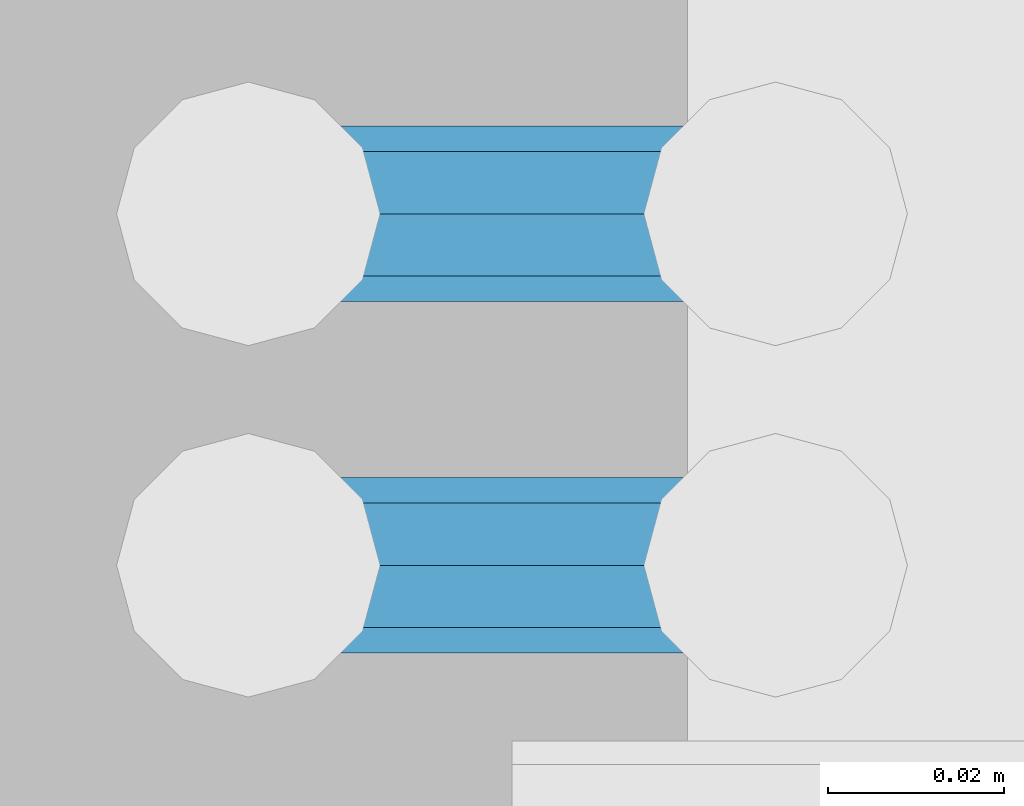
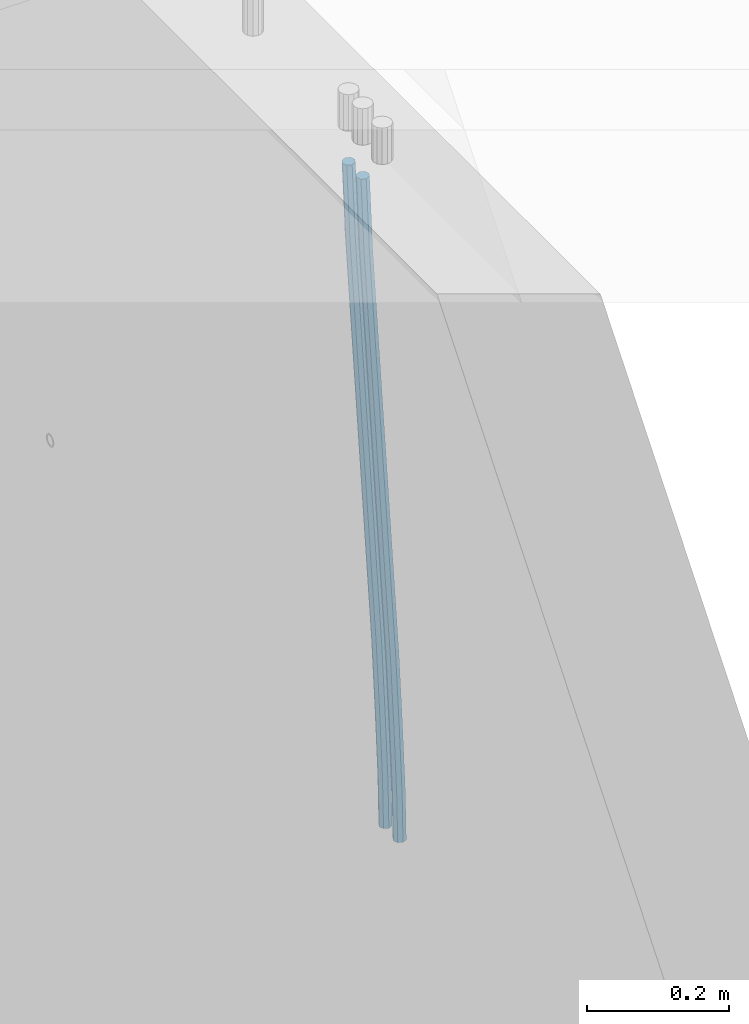
# One storey, part 110 of 350: 2 beams, 1 element without a shape of its own.
"""IFC2X3 building model written with IfcOpenShell, lengths in millimetres."""

from ifc_helpers import new_model, si_unit, frame, origin_with_axes, place, context, subcontext, project, spatial, faceted_brep, material, type_object, element, aggregate, save


model = new_model("IFC2X3")

# Units and contexts
model_context = context("Model", 3, precision=1e-05, world=origin_with_axes())
body_context = subcontext(model_context, "Body", "Model", "MODEL_VIEW")
ifc_project = project(units=[si_unit("LENGTHUNIT", "METRE", prefix="MILLI"), si_unit("AREAUNIT", "SQUARE_METRE"), si_unit("VOLUMEUNIT", "CUBIC_METRE"), si_unit("MASSUNIT", "GRAM", prefix="KILO"), si_unit("TIMEUNIT", "SECOND"), si_unit("PLANEANGLEUNIT", "RADIAN"), si_unit("SOLIDANGLEUNIT", "STERADIAN"), si_unit("THERMODYNAMICTEMPERATUREUNIT", "DEGREE_CELSIUS"), si_unit("LUMINOUSINTENSITYUNIT", "LUMEN")], contexts=[model_context])

# Site, building, storey
site_placement = place(None, origin_with_axes())
site = spatial("IfcSite", under=ifc_project, at=site_placement, CompositionType="ELEMENT")
building_placement = place(site_placement, origin_with_axes())
building = spatial("IfcBuilding", under=site, at=building_placement, CompositionType="ELEMENT")
storey_placement = place(building_placement, origin_with_axes())
storey = spatial("IfcBuildingStorey", under=building, at=storey_placement, Name="2", CompositionType="ELEMENT", Elevation=0.0)

# Assembly, beams
assembly_placement = place(storey_placement, origin_with_axes())
assembly = element("IfcElementAssembly", 1, at=assembly_placement, inside=storey, AssemblyPlace="NOTDEFINED", PredefinedType="REINFORCEMENT_UNIT")
ifc_material = material()
beam_type = type_object("IfcBeamType", Name="D20", PredefinedType="NOTDEFINED")
beam_1_placement = place(assembly_placement, frame((28670.0000022791, 9890.00000000393, 86242.5), z_axis=(-0.999820284539475, -0.000205762999905157, -0.0189566949912691), x_axis=(-0.0189566949945633, 3.09999984783362e-08, 0.999820305712423)))
beam_1 = element("IfcBeam", 2, at=beam_1_placement, type_object=beam_type, material=ifc_material, Name="JM20", ObjectType="D20", context=body_context, shape_type="Brep", body=[
    faceted_brep([(0.0, -10.0, 0.0), (-4.19531716033816e-08, -7.07106781186667, -7.07106781187031), (85.3814813058561, -7.07106783855306, -7.07106781027323), (85.3814813076606, -10.0000000266882, 1.58615875989199e-09), (0.0, 0.0, -10.0), (85.381481306933, -2.66882125288248e-08, -9.9999999984102), (4.196772351861e-08, 7.07106781186303, -7.07106781186667), (85.3814813102799, 7.07106778517664, -7.07106781027687), (0.0, 10.0, 0.0), (85.3814813139179, 9.99999997331361, 1.58979673869908e-09), (4.196772351861e-08, 7.07106781185939, 7.07106781185939), (85.3814813157223, 7.07106778517664, 7.07106781345647), (0.0, 0.0, 10.0), (85.3814813146601, -2.66863935394213e-08, 10.0000000015898), (-4.19531716033816e-08, -7.07106781187031, 7.07106781185939), (85.3814813113131, -7.07106783855306, 7.07106781345647), (86.0589861600893, -7.07106783876588, -7.07106781025868), (85.9854738744616, -10.0000000268774, 1.60071067512035e-09), (86.0894233170693, -2.69101292360574e-08, -9.99999999839565), (86.0589556716441, 7.07106778496563, -7.07106781026232), (85.9854307572532, 9.99999997312261, 1.60434865392745e-09), (85.9119184716255, 7.07106778501111, 7.07106781346374), (85.8814813146455, -2.68446456175298e-08, 10.0000000016007), (85.9119489600853, -7.07106783871859, 7.07106781346374), (86.7363445540104, -7.07106491765808, -7.05698116088388), (86.5893358725152, -9.99999742272485, 0.0125581869215239), (86.7972122870997, 3.02542866847944e-06, -9.98528050109235), (86.7362835792737, 7.07107070594066, -7.05698179489264), (86.5892496412271, 10.0000025770914, 0.0125572902979911), (86.4422409597319, 7.07107007202831, 7.08209663810703), (86.3813732266281, 2.12893792195246e-06, 10.0103959783119), (86.4423019344686, -7.07106555157225, 7.08209727211579), (201.576579767396, -7.07056966943492, -4.66871205216376), (201.429571085901, -9.99950217449987, 2.40082729564529), (201.637447500485, 0.00049827365182864, -7.59701139237222), (201.576518792659, 7.07156595416382, -4.66871268616887), (201.429484854598, 10.0004978253128, 2.40082639902175), (201.282476173117, 7.07156532024783, 9.47036574682716), (201.221608440013, 0.000497377159263124, 12.3986650870356), (201.282537147839, -7.07057030335091, 9.47036638083955), (202.132124882439, -7.07056727364943, -4.65715868644475), (201.96206784925, -9.99949987810942, 2.41190133749114), (202.202535595599, 0.000500710591950337, -7.58525956654921), (202.132054347894, 7.07156834990747, -4.65715951926177), (201.961968098345, 10.0005001216468, 2.41190015971006), (201.791911065156, 7.07156751718503, 9.48096018364595), (201.721500351996, 0.000499532941830694, 12.4090610637504), (201.791981599716, -7.07056810637368, 9.48096101645933), (202.687582846644, -7.07056412668317, -4.64198287962427), (202.494481077447, -9.99949686170658, 2.42644753327841), (202.767535042804, 0.000503911614941899, -7.5698230744747), (202.68750275379, 7.07157149682098, -4.64198397358632), (202.494367809079, 10.0005031379733, 2.42644598618062), (202.301266039882, 7.07157040295351, 9.4948763990833), (202.221313843707, 0.000502364651765674, 12.4227165939337), (202.301346132735, -7.07056522055063, 9.49487749304899), (324.551835950231, -7.0698737022467, -1.31249895472502), (324.358734181034, -9.99880643726465, 5.75593145817766), (324.631788146435, 0.00119433605323138, -4.24033914957545), (324.551755857465, 7.07226192125927, -1.31250004869435), (324.358620912724, 10.0011935624152, 5.75592991107987), (324.165519143527, 7.0722608273918, 12.8243603239825), (324.085566947324, 0.00119278909369314, 15.7522005188257), (324.165599236323, -7.06987479611053, 12.824361417941), (325.169986973066, -7.06987020009365, -1.29561029507749), (324.927897486399, -9.99880321110686, 5.771481712065), (325.270230817769, 0.001197953170049, -4.22289609669315), (325.169886630654, 7.0722654232959, -1.29561194228882), (324.927713770478, 10.0011967881728, 5.77147824025451), (324.685624283753, 7.0722637740655, 12.838570247397), (324.585380439035, 0.00119562080180913, 15.765856049009), (324.68572462615, -7.06987184932404, 12.8385718946047), (325.787844353894, -7.06986492748911, -1.27015109693093), (325.496748620091, -9.99879835819411, 5.79492186753487), (325.908370207922, 0.00120339885688736, -4.19660116572049), (325.7877237715, 7.07227069572764, -1.27015357813798), (325.496578090824, 10.0012016410783, 5.79491835858062), (325.205482357007, 7.0722682103733, 12.8599913230537), (325.084956502978, 0.00119988402911986, 15.786441391836), (325.205602939401, -7.06986741284345, 12.8599938042571), (1042.03161452286, -7.06375272341029, 28.2431194949422), (1041.74051878905, -9.99268615411529, 35.3081924594117), (1042.15214037691, 0.00731560293206712, 25.316669426149), (1042.03149394046, 7.07838289980646, 28.2431170137352), (1041.74034825979, 10.0073138451571, 35.3081889504501), (1041.44925252597, 7.07838041445029, 42.3732619149196), (1041.32872667194, 0.0073120881079376, 45.2997119837128), (1041.44937310836, -7.06375520876645, 42.3732643961303), (1042.53119058681, -7.06374846018116, 28.2637048377692), (1042.29202087625, -9.99268144776761, 35.3309174463611), (1042.66838856968, 0.00732000843709102, 25.3379417544274), (1042.62324610727, 7.07838794963754, 28.2675005302808), (1042.42220704176, 10.0073196639296, 35.3362853661929), (1042.1830373312, 7.07838667634496, 42.4034979747848), (1042.04583934831, 0.00731820772671199, 45.3292610581229), (1042.09098181075, -7.06374973347374, 42.3997022822768), (1043.03103703466, -7.070266625562, 28.2742424885473), (1042.84382145111, -9.99987711239555, 35.3425503824001), (1043.1849161698, 0.00058431523211766, 25.3488310735229), (1043.21531854615, 7.07066712639244, 28.2799824687318), (1043.10443486394, 9.99842318423725, 35.3506679402271), (1042.9172192804, 7.06881269740552, 42.4189758340799), (1042.76334014525, -0.00203824338677805, 45.3443872491043), (1042.7329377689, -7.07212105454892, 42.4132358538955), (1064.81738378434, -7.35436789656524, 28.7335373676506), (1064.63016820079, -10.283978383397, 35.8018452614997), (1064.97126291947, -0.28351695577112, 25.8081259526225), (1065.0016652958, 6.7865658553892, 28.739277347835), (1064.89078161362, 9.71432191323584, 35.8099628193268), (1064.70356603006, 6.78471142640228, 42.8782707131795), (1064.54968689493, -0.286139514393653, 45.8036821282076), (1064.51928451858, -7.35622232555033, 42.8725307329951), (1065.45272781498, -7.36265299588376, 28.7469315480957), (1065.29016895246, -10.2925850146312, 35.8157592494244), (1065.54948569229, -0.291057174725211, 25.82031591552), (1065.52376313217, 6.77975752443672, 28.7502840973975), (1065.39062806149, 9.707803747855, 35.8205004701085), (1065.22806919899, 6.77787172910939, 42.88932817143), (1065.13131132166, -0.293724092054617, 45.8159438040057), (1065.15703388178, -7.36453879121291, 42.8859756221354), (1066.08812716302, -7.36077623553683, 28.7601312146726), (1065.95022695855, -10.2906154014236, 35.8294784092541), (1066.12775920189, -0.289358859392451, 25.8323113164442), (1066.04590716431, 6.78129633325807, 28.7610959027625), (1065.89051886379, 9.70929542543126, 35.8308426842304), (1065.75261865935, 6.77945625954089, 42.9001898788119), (1065.71298662046, -0.291961116598031, 45.8280097770439), (1065.79483865805, -7.36261630925401, 42.8992251907257), (1166.09581212897, -7.06235299836771, 30.8346385453115), (1165.9579119245, -9.99219216425445, 37.903985739893), (1166.13544416784, 0.00906437777666724, 27.9068186470795), (1166.05359213027, 7.07971957042719, 30.8356032333941), (1165.89820382974, 10.0077186626022, 37.9053500148657), (1165.76030362528, 7.07787949671001, 44.9746972094508), (1165.72067158642, 0.00646212056926743, 47.9025171076792), (1165.80252362399, -7.06419307208489, 44.9737325213646)], [[[0, 1, 2, 3]], [[1, 4, 5, 2]], [[4, 6, 7, 5]], [[6, 8, 9, 7]], [[8, 10, 11, 9]], [[10, 12, 13, 11]], [[12, 14, 15, 13]], [[14, 0, 3, 15]], [[14, 12, 10, 8, 6, 4, 1, 0]], [[3, 2, 16, 17]], [[2, 5, 18, 16]], [[5, 7, 19, 18]], [[7, 9, 20, 19]], [[9, 11, 21, 20]], [[11, 13, 22, 21]], [[13, 15, 23, 22]], [[15, 3, 17, 23]], [[17, 16, 24, 25]], [[16, 18, 26, 24]], [[18, 19, 27, 26]], [[19, 20, 28, 27]], [[20, 21, 29, 28]], [[21, 22, 30, 29]], [[22, 23, 31, 30]], [[23, 17, 25, 31]], [[25, 24, 32, 33]], [[24, 26, 34, 32]], [[26, 27, 35, 34]], [[27, 28, 36, 35]], [[28, 29, 37, 36]], [[29, 30, 38, 37]], [[30, 31, 39, 38]], [[31, 25, 33, 39]], [[33, 32, 40, 41]], [[32, 34, 42, 40]], [[34, 35, 43, 42]], [[35, 36, 44, 43]], [[36, 37, 45, 44]], [[37, 38, 46, 45]], [[38, 39, 47, 46]], [[39, 33, 41, 47]], [[41, 40, 48, 49]], [[40, 42, 50, 48]], [[42, 43, 51, 50]], [[43, 44, 52, 51]], [[44, 45, 53, 52]], [[45, 46, 54, 53]], [[46, 47, 55, 54]], [[47, 41, 49, 55]], [[49, 48, 56, 57]], [[48, 50, 58, 56]], [[50, 51, 59, 58]], [[51, 52, 60, 59]], [[52, 53, 61, 60]], [[53, 54, 62, 61]], [[54, 55, 63, 62]], [[55, 49, 57, 63]], [[57, 56, 64, 65]], [[56, 58, 66, 64]], [[58, 59, 67, 66]], [[59, 60, 68, 67]], [[60, 61, 69, 68]], [[61, 62, 70, 69]], [[62, 63, 71, 70]], [[63, 57, 65, 71]], [[65, 64, 72, 73]], [[64, 66, 74, 72]], [[66, 67, 75, 74]], [[67, 68, 76, 75]], [[68, 69, 77, 76]], [[69, 70, 78, 77]], [[70, 71, 79, 78]], [[71, 65, 73, 79]], [[73, 72, 80, 81]], [[72, 74, 82, 80]], [[74, 75, 83, 82]], [[75, 76, 84, 83]], [[76, 77, 85, 84]], [[77, 78, 86, 85]], [[78, 79, 87, 86]], [[79, 73, 81, 87]], [[81, 80, 88, 89]], [[80, 82, 90, 88]], [[82, 83, 91, 90]], [[83, 84, 92, 91]], [[84, 85, 93, 92]], [[85, 86, 94, 93]], [[86, 87, 95, 94]], [[87, 81, 89, 95]], [[89, 88, 96, 97]], [[88, 90, 98, 96]], [[90, 91, 99, 98]], [[91, 92, 100, 99]], [[92, 93, 101, 100]], [[93, 94, 102, 101]], [[94, 95, 103, 102]], [[95, 89, 97, 103]], [[97, 96, 104, 105]], [[96, 98, 106, 104]], [[98, 99, 107, 106]], [[99, 100, 108, 107]], [[100, 101, 109, 108]], [[101, 102, 110, 109]], [[102, 103, 111, 110]], [[103, 97, 105, 111]], [[105, 104, 112, 113]], [[104, 106, 114, 112]], [[106, 107, 115, 114]], [[107, 108, 116, 115]], [[108, 109, 117, 116]], [[109, 110, 118, 117]], [[110, 111, 119, 118]], [[111, 105, 113, 119]], [[113, 112, 120, 121]], [[112, 114, 122, 120]], [[114, 115, 123, 122]], [[115, 116, 124, 123]], [[116, 117, 125, 124]], [[117, 118, 126, 125]], [[118, 119, 127, 126]], [[119, 113, 121, 127]], [[121, 120, 128, 129]], [[120, 122, 130, 128]], [[122, 123, 131, 130]], [[123, 124, 132, 131]], [[124, 125, 133, 132]], [[125, 126, 134, 133]], [[126, 127, 135, 134]], [[127, 121, 129, 135]], [[130, 131, 132, 133, 134, 135, 129, 128]]]),
])
beam_2_placement = place(assembly_placement, frame((28670.0000022791, 9930.00000000393, 86242.5), z_axis=(-0.999820284539475, -0.000205762999905157, -0.0189566949912691), x_axis=(-0.0189566949945633, 3.09999984783362e-08, 0.999820305712423)))
beam_2 = element("IfcBeam", 3, at=beam_2_placement, type_object=beam_type, material=ifc_material, Name="JM20", ObjectType="D20", context=body_context, shape_type="Brep", body=[
    faceted_brep([(0.0, -10.0, 0.0), (-4.19531716033816e-08, -7.07106781186667, -7.07106781187031), (85.3814813058561, -7.07106783855306, -7.07106781027323), (85.3814813076606, -10.0000000266882, 1.58615875989199e-09), (0.0, 0.0, -10.0), (85.381481306933, -2.66882125288248e-08, -9.9999999984102), (4.196772351861e-08, 7.07106781186303, -7.07106781186667), (85.3814813102799, 7.07106778517664, -7.07106781027687), (0.0, 10.0, 0.0), (85.3814813139179, 9.99999997331361, 1.58979673869908e-09), (4.196772351861e-08, 7.07106781185939, 7.07106781185939), (85.3814813157223, 7.07106778517664, 7.07106781345647), (0.0, 0.0, 10.0), (85.3814813146601, -2.66863935394213e-08, 10.0000000015898), (-4.19531716033816e-08, -7.07106781187031, 7.07106781185939), (85.3814813113131, -7.07106783855306, 7.07106781345647), (86.0589861600893, -7.07106783876588, -7.07106781025868), (85.9854738744616, -10.0000000268774, 1.60071067512035e-09), (86.0894233170693, -2.69101292360574e-08, -9.99999999839565), (86.0589556716441, 7.07106778496563, -7.07106781026232), (85.9854307572532, 9.99999997312261, 1.60434865392745e-09), (85.9119184716255, 7.07106778501111, 7.07106781346374), (85.8814813146455, -2.68446456175298e-08, 10.0000000016007), (85.9119489600853, -7.07106783871859, 7.07106781346374), (86.7363445540104, -7.07106491765808, -7.05698116088388), (86.5893358725152, -9.99999742272485, 0.0125581869215239), (86.7972122870997, 3.02542866847944e-06, -9.98528050109235), (86.7362835792737, 7.07107070594066, -7.05698179489264), (86.5892496412271, 10.0000025770914, 0.0125572902979911), (86.4422409597319, 7.07107007202831, 7.08209663810703), (86.3813732266281, 2.12893792195246e-06, 10.0103959783119), (86.4423019344686, -7.07106555157225, 7.08209727211579), (201.576579767396, -7.07056966943492, -4.66871205216376), (201.429571085901, -9.99950217449987, 2.40082729564529), (201.637447500485, 0.00049827365182864, -7.59701139237222), (201.576518792659, 7.07156595416382, -4.66871268616887), (201.429484854598, 10.0004978253128, 2.40082639902175), (201.282476173117, 7.07156532024783, 9.47036574682716), (201.221608440013, 0.000497377159263124, 12.3986650870356), (201.282537147839, -7.07057030335091, 9.47036638083955), (202.132124882439, -7.07056727364943, -4.65715868644475), (201.96206784925, -9.99949987810942, 2.41190133749114), (202.202535595599, 0.000500710591950337, -7.58525956654921), (202.132054347894, 7.07156834990747, -4.65715951926177), (201.961968098345, 10.0005001216468, 2.41190015971006), (201.791911065156, 7.07156751718503, 9.48096018364595), (201.721500351996, 0.000499532941830694, 12.4090610637504), (201.791981599716, -7.07056810637368, 9.48096101645933), (202.687582846644, -7.07056412668317, -4.64198287962427), (202.494481077447, -9.99949686170658, 2.42644753327841), (202.767535042804, 0.000503911614941899, -7.5698230744747), (202.68750275379, 7.07157149682098, -4.64198397358632), (202.494367809079, 10.0005031379733, 2.42644598618062), (202.301266039882, 7.07157040295351, 9.4948763990833), (202.221313843707, 0.000502364651765674, 12.4227165939337), (202.301346132735, -7.07056522055063, 9.49487749304899), (324.551835950231, -7.0698737022467, -1.31249895472502), (324.358734181034, -9.99880643726465, 5.75593145817766), (324.631788146435, 0.00119433605323138, -4.24033914957545), (324.551755857465, 7.07226192125927, -1.31250004869435), (324.358620912724, 10.0011935624152, 5.75592991107987), (324.165519143527, 7.0722608273918, 12.8243603239825), (324.085566947324, 0.00119278909369314, 15.7522005188257), (324.165599236323, -7.06987479611053, 12.824361417941), (325.169986973066, -7.06987020009365, -1.29561029507749), (324.927897486399, -9.99880321110686, 5.771481712065), (325.270230817769, 0.001197953170049, -4.22289609669315), (325.169886630654, 7.0722654232959, -1.29561194228882), (324.927713770478, 10.0011967881728, 5.77147824025451), (324.685624283753, 7.0722637740655, 12.838570247397), (324.585380439035, 0.00119562080180913, 15.765856049009), (324.68572462615, -7.06987184932404, 12.8385718946047), (325.787844353894, -7.06986492748911, -1.27015109693093), (325.496748620091, -9.99879835819411, 5.79492186753487), (325.908370207922, 0.00120339885688736, -4.19660116572049), (325.7877237715, 7.07227069572764, -1.27015357813798), (325.496578090824, 10.0012016410783, 5.79491835858062), (325.205482357007, 7.0722682103733, 12.8599913230537), (325.084956502978, 0.00119988402911986, 15.786441391836), (325.205602939401, -7.06986741284345, 12.8599938042571), (1042.03161452286, -7.06375272341029, 28.2431194949422), (1041.74051878905, -9.99268615411529, 35.3081924594117), (1042.15214037691, 0.00731560293206712, 25.316669426149), (1042.03149394046, 7.07838289980646, 28.2431170137352), (1041.74034825979, 10.0073138451571, 35.3081889504501), (1041.44925252597, 7.07838041445029, 42.3732619149196), (1041.32872667194, 0.0073120881079376, 45.2997119837128), (1041.44937310836, -7.06375520876645, 42.3732643961303), (1042.53119058681, -7.06374846018116, 28.2637048377692), (1042.29202087625, -9.99268144776761, 35.3309174463611), (1042.66838856968, 0.00732000843709102, 25.3379417544274), (1042.62324610727, 7.07838794963754, 28.2675005302808), (1042.42220704176, 10.0073196639296, 35.3362853661929), (1042.1830373312, 7.07838667634496, 42.4034979747848), (1042.04583934831, 0.00731820772671199, 45.3292610581229), (1042.09098181075, -7.06374973347374, 42.3997022822768), (1043.03103703466, -7.070266625562, 28.2742424885473), (1042.84382145111, -9.99987711239555, 35.3425503824001), (1043.1849161698, 0.00058431523211766, 25.3488310735229), (1043.21531854615, 7.07066712639244, 28.2799824687318), (1043.10443486394, 9.99842318423725, 35.3506679402271), (1042.9172192804, 7.06881269740552, 42.4189758340799), (1042.76334014525, -0.00203824338677805, 45.3443872491043), (1042.7329377689, -7.07212105454892, 42.4132358538955), (1064.81738378434, -7.35436789656524, 28.7335373676506), (1064.63016820079, -10.283978383397, 35.8018452614997), (1064.97126291947, -0.28351695577112, 25.8081259526225), (1065.0016652958, 6.7865658553892, 28.739277347835), (1064.89078161362, 9.71432191323584, 35.8099628193268), (1064.70356603006, 6.78471142640228, 42.8782707131795), (1064.54968689493, -0.286139514393653, 45.8036821282076), (1064.51928451858, -7.35622232555033, 42.8725307329951), (1065.45272781498, -7.36265299588376, 28.7469315480957), (1065.29016895246, -10.2925850146312, 35.8157592494244), (1065.54948569229, -0.291057174725211, 25.82031591552), (1065.52376313217, 6.77975752443672, 28.7502840973975), (1065.39062806149, 9.707803747855, 35.8205004701085), (1065.22806919899, 6.77787172910939, 42.88932817143), (1065.13131132166, -0.293724092054617, 45.8159438040057), (1065.15703388178, -7.36453879121291, 42.8859756221354), (1066.08812716302, -7.36077623553683, 28.7601312146726), (1065.95022695855, -10.2906154014236, 35.8294784092541), (1066.12775920189, -0.289358859392451, 25.8323113164442), (1066.04590716431, 6.78129633325807, 28.7610959027625), (1065.89051886379, 9.70929542543126, 35.8308426842304), (1065.75261865935, 6.77945625954089, 42.9001898788119), (1065.71298662046, -0.291961116598031, 45.8280097770439), (1065.79483865805, -7.36261630925401, 42.8992251907257), (1166.09581212897, -7.06235299836771, 30.8346385453115), (1165.9579119245, -9.99219216425445, 37.903985739893), (1166.13544416784, 0.00906437777666724, 27.9068186470795), (1166.05359213027, 7.07971957042719, 30.8356032333941), (1165.89820382974, 10.0077186626022, 37.9053500148657), (1165.76030362528, 7.07787949671001, 44.9746972094508), (1165.72067158642, 0.00646212056926743, 47.9025171076792), (1165.80252362399, -7.06419307208489, 44.9737325213646)], [[[0, 1, 2, 3]], [[1, 4, 5, 2]], [[4, 6, 7, 5]], [[6, 8, 9, 7]], [[8, 10, 11, 9]], [[10, 12, 13, 11]], [[12, 14, 15, 13]], [[14, 0, 3, 15]], [[14, 12, 10, 8, 6, 4, 1, 0]], [[3, 2, 16, 17]], [[2, 5, 18, 16]], [[5, 7, 19, 18]], [[7, 9, 20, 19]], [[9, 11, 21, 20]], [[11, 13, 22, 21]], [[13, 15, 23, 22]], [[15, 3, 17, 23]], [[17, 16, 24, 25]], [[16, 18, 26, 24]], [[18, 19, 27, 26]], [[19, 20, 28, 27]], [[20, 21, 29, 28]], [[21, 22, 30, 29]], [[22, 23, 31, 30]], [[23, 17, 25, 31]], [[25, 24, 32, 33]], [[24, 26, 34, 32]], [[26, 27, 35, 34]], [[27, 28, 36, 35]], [[28, 29, 37, 36]], [[29, 30, 38, 37]], [[30, 31, 39, 38]], [[31, 25, 33, 39]], [[33, 32, 40, 41]], [[32, 34, 42, 40]], [[34, 35, 43, 42]], [[35, 36, 44, 43]], [[36, 37, 45, 44]], [[37, 38, 46, 45]], [[38, 39, 47, 46]], [[39, 33, 41, 47]], [[41, 40, 48, 49]], [[40, 42, 50, 48]], [[42, 43, 51, 50]], [[43, 44, 52, 51]], [[44, 45, 53, 52]], [[45, 46, 54, 53]], [[46, 47, 55, 54]], [[47, 41, 49, 55]], [[49, 48, 56, 57]], [[48, 50, 58, 56]], [[50, 51, 59, 58]], [[51, 52, 60, 59]], [[52, 53, 61, 60]], [[53, 54, 62, 61]], [[54, 55, 63, 62]], [[55, 49, 57, 63]], [[57, 56, 64, 65]], [[56, 58, 66, 64]], [[58, 59, 67, 66]], [[59, 60, 68, 67]], [[60, 61, 69, 68]], [[61, 62, 70, 69]], [[62, 63, 71, 70]], [[63, 57, 65, 71]], [[65, 64, 72, 73]], [[64, 66, 74, 72]], [[66, 67, 75, 74]], [[67, 68, 76, 75]], [[68, 69, 77, 76]], [[69, 70, 78, 77]], [[70, 71, 79, 78]], [[71, 65, 73, 79]], [[73, 72, 80, 81]], [[72, 74, 82, 80]], [[74, 75, 83, 82]], [[75, 76, 84, 83]], [[76, 77, 85, 84]], [[77, 78, 86, 85]], [[78, 79, 87, 86]], [[79, 73, 81, 87]], [[81, 80, 88, 89]], [[80, 82, 90, 88]], [[82, 83, 91, 90]], [[83, 84, 92, 91]], [[84, 85, 93, 92]], [[85, 86, 94, 93]], [[86, 87, 95, 94]], [[87, 81, 89, 95]], [[89, 88, 96, 97]], [[88, 90, 98, 96]], [[90, 91, 99, 98]], [[91, 92, 100, 99]], [[92, 93, 101, 100]], [[93, 94, 102, 101]], [[94, 95, 103, 102]], [[95, 89, 97, 103]], [[97, 96, 104, 105]], [[96, 98, 106, 104]], [[98, 99, 107, 106]], [[99, 100, 108, 107]], [[100, 101, 109, 108]], [[101, 102, 110, 109]], [[102, 103, 111, 110]], [[103, 97, 105, 111]], [[105, 104, 112, 113]], [[104, 106, 114, 112]], [[106, 107, 115, 114]], [[107, 108, 116, 115]], [[108, 109, 117, 116]], [[109, 110, 118, 117]], [[110, 111, 119, 118]], [[111, 105, 113, 119]], [[113, 112, 120, 121]], [[112, 114, 122, 120]], [[114, 115, 123, 122]], [[115, 116, 124, 123]], [[116, 117, 125, 124]], [[117, 118, 126, 125]], [[118, 119, 127, 126]], [[119, 113, 121, 127]], [[121, 120, 128, 129]], [[120, 122, 130, 128]], [[122, 123, 131, 130]], [[123, 124, 132, 131]], [[124, 125, 133, 132]], [[125, 126, 134, 133]], [[126, 127, 135, 134]], [[127, 121, 129, 135]], [[130, 131, 132, 133, 134, 135, 129, 128]]]),
])
aggregate(assembly, [beam_1, beam_2])

save(model, "model.ifc")
